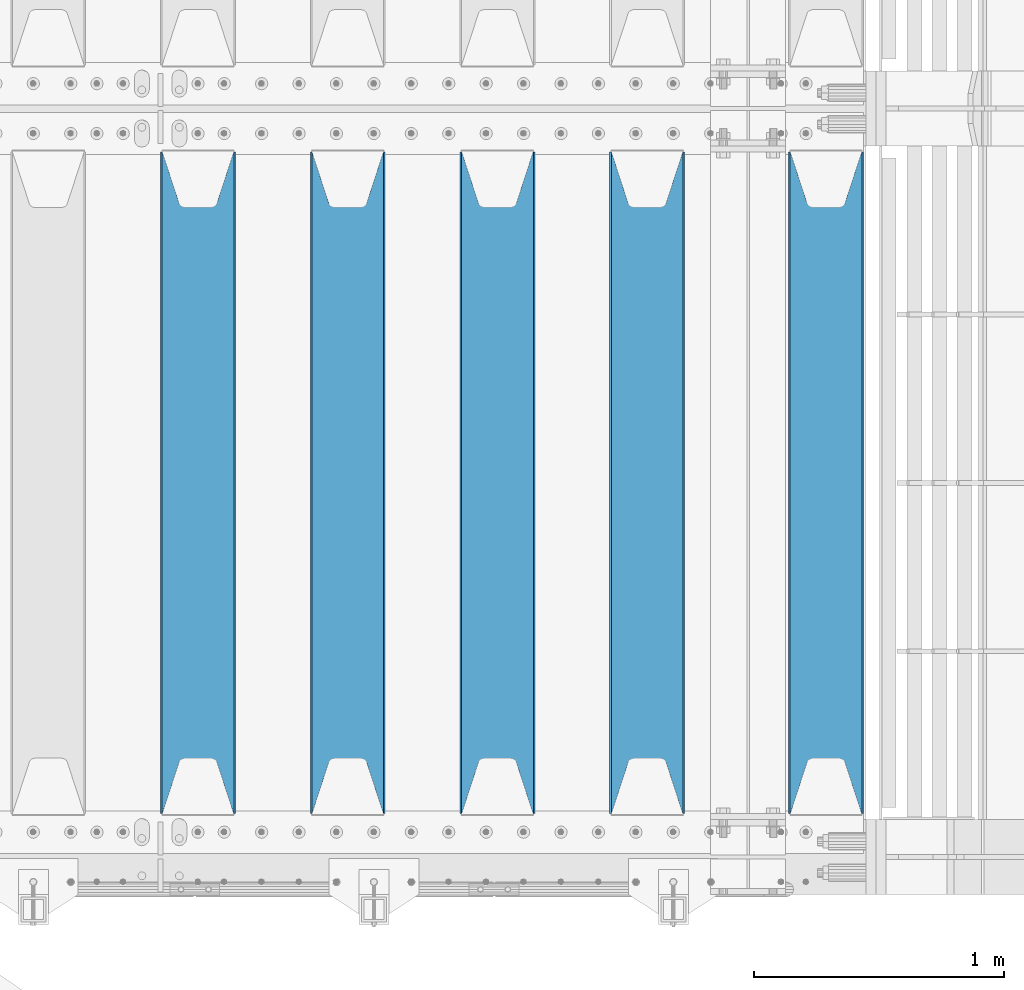
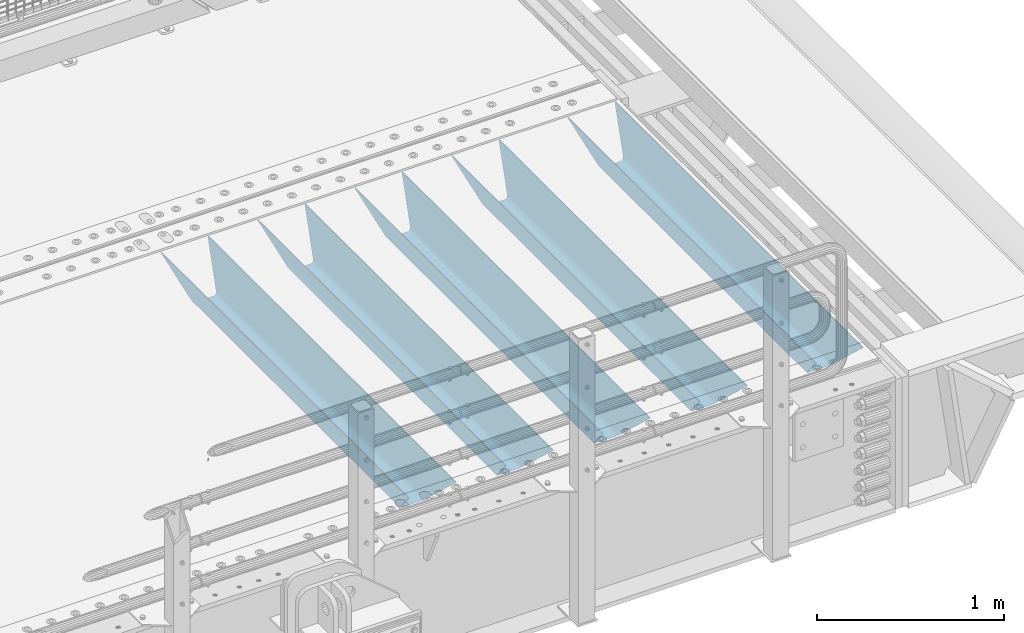
# One storey, part 96 of 193: 5 beams.
"""IFC2X3 building model written with IfcOpenShell, lengths in millimetres."""

from ifc_helpers import new_model, si_unit, frame, origin_with_axes, place, context, subcontext, project, spatial, faceted_brep, material, type_object, element, save


model = new_model("IFC2X3")

# Units and contexts
model_context = context("Model", 3, precision=1e-05, world=origin_with_axes())
body_context = subcontext(model_context, "Body", "Model", "MODEL_VIEW")
ifc_project = project(units=[si_unit("LENGTHUNIT", "METRE", prefix="MILLI"), si_unit("AREAUNIT", "SQUARE_METRE"), si_unit("VOLUMEUNIT", "CUBIC_METRE"), si_unit("MASSUNIT", "GRAM", prefix="KILO"), si_unit("TIMEUNIT", "SECOND"), si_unit("PLANEANGLEUNIT", "RADIAN"), si_unit("SOLIDANGLEUNIT", "STERADIAN"), si_unit("THERMODYNAMICTEMPERATUREUNIT", "DEGREE_CELSIUS"), si_unit("LUMINOUSINTENSITYUNIT", "LUMEN")], contexts=[model_context])

# Site, building, storey
site_placement = place(None, origin_with_axes())
site = spatial("IfcSite", under=ifc_project, at=site_placement, CompositionType="ELEMENT")
building_placement = place(site_placement, origin_with_axes())
building = spatial("IfcBuilding", under=site, at=building_placement, Name="Standard", CompositionType="ELEMENT")
storey_placement = place(building_placement, origin_with_axes())
storey = spatial("IfcBuildingStorey", under=building, at=storey_placement, Name="Undefined", CompositionType="ELEMENT", Elevation=0.0)

# Beams
ifc_material = material(Name="STEEL/S355N")
beam_type = type_object("IfcBeamType", PredefinedType="NOTDEFINED")
beam_1_placement = place(storey_placement, frame((-28583.0, 24175.0, -115.0), z_axis=(0.0, 0.0, 1.0), x_axis=(0.0, 1.0, 0.0)))
element("IfcBeam", 1, at=beam_1_placement, inside=storey, type_object=beam_type, material=ifc_material, context=body_context, shape_type="Brep", body=[
    faceted_brep([(0.0, 150.0, 115.0), (0.0, 143.689999999999, 115.0), (2650.00000000297, 143.689999999999, 115.0), (2650.00000000297, 150.0, 115.0), (2650.00000000297, 142.059565218398, 110.000000003094), (2650.00000000297, 148.3695652184, 110.000000003094), (2441.90079219209, -80.1103600731112, -98.0992078077845), (2437.7588105432, -77.5672621345584, -102.241189456673), (2434.06523489747, -74.4080125315522, -105.934765102404), (2430.9108609509, -70.710272125576, -109.089139048974), (2428.37322971128, -66.5649389910068, -111.626770288588), (2426.51472138055, -62.0739139532889, -113.485278619323), (2425.38102192092, -57.3475956567672, -114.618978078955), (2424.99999999988, -52.5021667386536, -115.0), (2424.99999999988, 52.5021667386536, -115.0), (2425.38102192092, 57.3475956567672, -114.618978078955), (2426.51472138055, 62.0739139532889, -113.485278619323), (2428.37322971128, 66.5649389910068, -111.626770288588), (2430.9108609509, 70.710272125576, -109.089139048974), (2434.06523489747, 74.4080125315522, -105.934765102404), (2437.7588105432, 77.5672621345584, -102.241189456673), (2441.90079219209, 80.1103600731112, -98.0992078077846), (2446.38936140512, 81.9747917625791, -93.6106385947584), (2448.2494850041, 76.2713538057251, -91.7505149957729), (2444.62967112263, 74.76777986261, -95.3703288772456), (2441.28936334127, 72.7168944282894, -98.710636658607), (2438.31067330439, 70.1691124903846, -101.689326695487), (2435.76682334748, 67.1870637758839, -104.233176652398), (2433.72034654134, 63.8440531834895, -106.279653458539), (2432.22154950042, 60.222258798236, -107.778450499454), (2431.30727574265, 56.4107117849089, -108.692724257221), (2430.99999999987, 52.5031078186876, -109.0), (2430.99999999987, -52.5031078186876, -109.0), (2431.30727574265, -56.4107117849089, -108.692724257221), (2432.22154950042, -60.222258798236, -107.778450499454), (2433.72034654134, -63.8440531834895, -106.279653458539), (2435.76682334748, -67.1870637758839, -104.233176652398), (2438.31067330439, -70.1691124903846, -101.689326695487), (2441.28936334127, -72.7168944282894, -98.7106366586071), (2444.62967112263, -74.76777986261, -95.3703288772457), (2448.2494850041, -76.2713538057251, -91.7505149957729), (2650.00000000297, -142.059565218398, 110.000000003094), (2650.00000000297, -148.3695652184, 110.000000003094), (2446.38936140512, -81.9747917625791, -93.6106385947584), (2650.00000000297, -143.689999999999, 115.0), (2650.00000000297, -150.0, 115.0), (0.0, -143.689999999999, 115.0), (0.0, -150.0, 115.0), (0.0, -148.369565218261, 110.000000002667), (203.610638597427, -81.9747917625791, -93.6106385947584), (208.099207810446, -80.1103600731112, -98.0992078077845), (212.241189459342, -77.5672621345584, -102.241189456673), (215.93476510507, -74.4080125315522, -105.934765102404), (219.089139051641, -70.710272125576, -109.089139048974), (221.626770291256, -66.5649389910068, -111.626770288588), (223.485278621989, -62.0739139532889, -113.485278619323), (224.618978081624, -57.3475956567672, -114.618978078955), (225.000000002663, -52.5021667386536, -115.0), (225.000000002663, 52.5021667386536, -115.0), (224.618978081624, 57.3475956567672, -114.618978078955), (223.485278621989, 62.0739139532889, -113.485278619323), (221.626770291256, 66.5649389910068, -111.626770288588), (219.089139051641, 70.710272125576, -109.089139048974), (215.93476510507, 74.4080125315522, -105.934765102404), (212.241189459342, 77.5672621345584, -102.241189456673), (208.099207810446, 80.1103600731112, -98.0992078077846), (203.610638597427, 81.9747917625791, -93.6106385947584), (0.0, 148.369565218261, 110.000000002667), (0.0, 142.05956521826, 110.000000002667), (201.750514998439, 76.2713538057251, -91.7505149957729), (205.370328879915, 74.76777986261, -95.3703288772456), (208.710636661275, 72.7168944282894, -98.710636658607), (211.689326698157, 70.1691124903846, -101.689326695487), (214.233176655063, 67.1870637758839, -104.233176652398), (216.279653461206, 63.8440531834895, -106.279653458539), (217.778450502123, 60.222258798236, -107.778450499454), (218.69272425989, 56.4107117849089, -108.692724257221), (219.00000000267, 52.5031078186876, -109.0), (219.00000000267, -52.5031078186876, -109.0), (218.69272425989, -56.4107117849089, -108.692724257221), (217.778450502123, -60.222258798236, -107.778450499454), (216.279653461206, -63.8440531834895, -106.279653458539), (214.233176655063, -67.1870637758839, -104.233176652398), (211.689326698157, -70.1691124903846, -101.689326695487), (208.710636661275, -72.7168944282894, -98.7106366586071), (205.370328879915, -74.76777986261, -95.3703288772457), (201.750514998439, -76.2713538057251, -91.7505149957729), (0.0, -142.05956521826, 110.000000002667)], [[[0, 1, 2, 3]], [[3, 2, 4, 5]], [[6, 7, 8, 9, 10, 11, 12, 13, 14, 15, 16, 17, 18, 19, 20, 21, 22, 5, 4, 23, 24, 25, 26, 27, 28, 29, 30, 31, 32, 33, 34, 35, 36, 37, 38, 39, 40, 41, 42, 43]], [[44, 45, 42, 41]], [[46, 47, 45, 44]], [[43, 42, 45, 47, 48, 49]], [[6, 43, 49, 50]], [[7, 6, 50, 51]], [[8, 7, 51, 52]], [[9, 8, 52, 53]], [[10, 9, 53, 54]], [[11, 10, 54, 55]], [[12, 11, 55, 56]], [[13, 12, 56, 57]], [[14, 13, 57, 58]], [[15, 14, 58, 59]], [[16, 15, 59, 60]], [[17, 16, 60, 61]], [[18, 17, 61, 62]], [[19, 18, 62, 63]], [[20, 19, 63, 64]], [[21, 20, 64, 65]], [[22, 21, 65, 66]], [[0, 3, 5, 22, 66, 67]], [[1, 0, 67, 68]], [[23, 4, 2, 1, 68, 69]], [[24, 23, 69, 70]], [[25, 24, 70, 71]], [[26, 25, 71, 72]], [[27, 26, 72, 73]], [[28, 27, 73, 74]], [[29, 28, 74, 75]], [[30, 29, 75, 76]], [[31, 30, 76, 77]], [[32, 31, 77, 78]], [[33, 32, 78, 79]], [[34, 33, 79, 80]], [[35, 34, 80, 81]], [[36, 35, 81, 82]], [[37, 36, 82, 83]], [[38, 37, 83, 84]], [[39, 38, 84, 85]], [[40, 39, 85, 86]], [[46, 44, 41, 40, 86, 87]], [[47, 46, 87, 48]], [[86, 85, 84, 83, 82, 81, 80, 79, 78, 77, 76, 75, 74, 73, 72, 71, 70, 69, 68, 67, 66, 65, 64, 63, 62, 61, 60, 59, 58, 57, 56, 55, 54, 53, 52, 51, 50, 49, 48, 87]]]),
])
beam_2_placement = place(storey_placement, frame((-29300.0, 24175.0, -115.0), z_axis=(0.0, 0.0, 1.0), x_axis=(0.0, 1.0, 0.0)))
element("IfcBeam", 2, at=beam_2_placement, inside=storey, type_object=beam_type, material=ifc_material, context=body_context, shape_type="Brep", body=[
    faceted_brep([(0.0, 150.0, 115.0), (0.0, 143.689999999999, 115.0), (2650.00000000297, 143.689999999999, 115.0), (2650.00000000297, 150.0, 115.0), (2650.00000000297, 142.059565218398, 110.000000003094), (2650.00000000297, 148.3695652184, 110.000000003094), (2441.90079219209, -80.1103600731112, -98.0992078077845), (2437.7588105432, -77.5672621345584, -102.241189456673), (2434.06523489747, -74.4080125315522, -105.934765102404), (2430.9108609509, -70.710272125576, -109.089139048974), (2428.37322971128, -66.5649389910068, -111.626770288588), (2426.51472138055, -62.0739139532889, -113.485278619323), (2425.38102192092, -57.3475956567672, -114.618978078955), (2424.99999999988, -52.5021667386536, -115.0), (2424.99999999988, 52.5021667386536, -115.0), (2425.38102192092, 57.3475956567672, -114.618978078955), (2426.51472138055, 62.0739139532889, -113.485278619323), (2428.37322971128, 66.5649389910068, -111.626770288588), (2430.9108609509, 70.710272125576, -109.089139048974), (2434.06523489747, 74.4080125315522, -105.934765102404), (2437.7588105432, 77.5672621345584, -102.241189456673), (2441.90079219209, 80.1103600731112, -98.0992078077846), (2446.38936140512, 81.9747917625791, -93.6106385947584), (2448.2494850041, 76.2713538057251, -91.7505149957729), (2444.62967112263, 74.76777986261, -95.3703288772456), (2441.28936334127, 72.7168944282894, -98.710636658607), (2438.31067330439, 70.1691124903846, -101.689326695487), (2435.76682334748, 67.1870637758839, -104.233176652398), (2433.72034654134, 63.8440531834895, -106.279653458539), (2432.22154950042, 60.222258798236, -107.778450499454), (2431.30727574265, 56.4107117849089, -108.692724257221), (2430.99999999987, 52.5031078186876, -109.0), (2430.99999999987, -52.5031078186876, -109.0), (2431.30727574265, -56.4107117849089, -108.692724257221), (2432.22154950042, -60.222258798236, -107.778450499454), (2433.72034654134, -63.8440531834895, -106.279653458539), (2435.76682334748, -67.1870637758839, -104.233176652398), (2438.31067330439, -70.1691124903846, -101.689326695487), (2441.28936334127, -72.7168944282894, -98.7106366586071), (2444.62967112263, -74.76777986261, -95.3703288772457), (2448.2494850041, -76.2713538057251, -91.7505149957729), (2650.00000000297, -142.059565218398, 110.000000003094), (2650.00000000297, -148.3695652184, 110.000000003094), (2446.38936140512, -81.9747917625791, -93.6106385947584), (2650.00000000297, -143.689999999999, 115.0), (2650.00000000297, -150.0, 115.0), (0.0, -143.689999999999, 115.0), (0.0, -150.0, 115.0), (0.0, -148.369565218261, 110.000000002667), (203.610638597427, -81.9747917625791, -93.6106385947584), (208.099207810446, -80.1103600731112, -98.0992078077845), (212.241189459342, -77.5672621345584, -102.241189456673), (215.93476510507, -74.4080125315522, -105.934765102404), (219.089139051641, -70.710272125576, -109.089139048974), (221.626770291256, -66.5649389910068, -111.626770288588), (223.485278621989, -62.0739139532889, -113.485278619323), (224.618978081624, -57.3475956567672, -114.618978078955), (225.000000002663, -52.5021667386536, -115.0), (225.000000002663, 52.5021667386536, -115.0), (224.618978081624, 57.3475956567672, -114.618978078955), (223.485278621989, 62.0739139532889, -113.485278619323), (221.626770291256, 66.5649389910068, -111.626770288588), (219.089139051641, 70.710272125576, -109.089139048974), (215.93476510507, 74.4080125315522, -105.934765102404), (212.241189459342, 77.5672621345584, -102.241189456673), (208.099207810446, 80.1103600731112, -98.0992078077846), (203.610638597427, 81.9747917625791, -93.6106385947584), (0.0, 148.369565218261, 110.000000002667), (0.0, 142.05956521826, 110.000000002667), (201.750514998439, 76.2713538057251, -91.7505149957729), (205.370328879915, 74.76777986261, -95.3703288772456), (208.710636661275, 72.7168944282894, -98.710636658607), (211.689326698157, 70.1691124903846, -101.689326695487), (214.233176655063, 67.1870637758839, -104.233176652398), (216.279653461206, 63.8440531834895, -106.279653458539), (217.778450502123, 60.222258798236, -107.778450499454), (218.69272425989, 56.4107117849089, -108.692724257221), (219.00000000267, 52.5031078186876, -109.0), (219.00000000267, -52.5031078186876, -109.0), (218.69272425989, -56.4107117849089, -108.692724257221), (217.778450502123, -60.222258798236, -107.778450499454), (216.279653461206, -63.8440531834895, -106.279653458539), (214.233176655063, -67.1870637758839, -104.233176652398), (211.689326698157, -70.1691124903846, -101.689326695487), (208.710636661275, -72.7168944282894, -98.7106366586071), (205.370328879915, -74.76777986261, -95.3703288772457), (201.750514998439, -76.2713538057251, -91.7505149957729), (0.0, -142.05956521826, 110.000000002667)], [[[0, 1, 2, 3]], [[3, 2, 4, 5]], [[6, 7, 8, 9, 10, 11, 12, 13, 14, 15, 16, 17, 18, 19, 20, 21, 22, 5, 4, 23, 24, 25, 26, 27, 28, 29, 30, 31, 32, 33, 34, 35, 36, 37, 38, 39, 40, 41, 42, 43]], [[44, 45, 42, 41]], [[46, 47, 45, 44]], [[43, 42, 45, 47, 48, 49]], [[6, 43, 49, 50]], [[7, 6, 50, 51]], [[8, 7, 51, 52]], [[9, 8, 52, 53]], [[10, 9, 53, 54]], [[11, 10, 54, 55]], [[12, 11, 55, 56]], [[13, 12, 56, 57]], [[14, 13, 57, 58]], [[15, 14, 58, 59]], [[16, 15, 59, 60]], [[17, 16, 60, 61]], [[18, 17, 61, 62]], [[19, 18, 62, 63]], [[20, 19, 63, 64]], [[21, 20, 64, 65]], [[22, 21, 65, 66]], [[0, 3, 5, 22, 66, 67]], [[1, 0, 67, 68]], [[23, 4, 2, 1, 68, 69]], [[24, 23, 69, 70]], [[25, 24, 70, 71]], [[26, 25, 71, 72]], [[27, 26, 72, 73]], [[28, 27, 73, 74]], [[29, 28, 74, 75]], [[30, 29, 75, 76]], [[31, 30, 76, 77]], [[32, 31, 77, 78]], [[33, 32, 78, 79]], [[34, 33, 79, 80]], [[35, 34, 80, 81]], [[36, 35, 81, 82]], [[37, 36, 82, 83]], [[38, 37, 83, 84]], [[39, 38, 84, 85]], [[40, 39, 85, 86]], [[46, 44, 41, 40, 86, 87]], [[47, 46, 87, 48]], [[86, 85, 84, 83, 82, 81, 80, 79, 78, 77, 76, 75, 74, 73, 72, 71, 70, 69, 68, 67, 66, 65, 64, 63, 62, 61, 60, 59, 58, 57, 56, 55, 54, 53, 52, 51, 50, 49, 48, 87]]]),
])
beam_3_placement = place(storey_placement, frame((-29900.0, 24175.0, -115.0), z_axis=(0.0, 0.0, 1.0), x_axis=(0.0, 1.0, 0.0)))
element("IfcBeam", 3, at=beam_3_placement, inside=storey, type_object=beam_type, material=ifc_material, context=body_context, shape_type="Brep", body=[
    faceted_brep([(0.0, 150.0, 115.0), (0.0, 143.689999999999, 115.0), (2650.00000000297, 143.689999999999, 115.0), (2650.00000000297, 150.0, 115.0), (2650.00000000297, 142.059565218398, 110.000000003094), (2650.00000000297, 148.3695652184, 110.000000003094), (2441.90079219209, -80.1103600731112, -98.0992078077845), (2437.7588105432, -77.5672621345584, -102.241189456673), (2434.06523489747, -74.4080125315522, -105.934765102404), (2430.9108609509, -70.710272125576, -109.089139048974), (2428.37322971128, -66.5649389910068, -111.626770288588), (2426.51472138055, -62.0739139532889, -113.485278619323), (2425.38102192092, -57.3475956567672, -114.618978078955), (2424.99999999988, -52.5021667386536, -115.0), (2424.99999999988, 52.5021667386536, -115.0), (2425.38102192092, 57.3475956567672, -114.618978078955), (2426.51472138055, 62.0739139532889, -113.485278619323), (2428.37322971128, 66.5649389910068, -111.626770288588), (2430.9108609509, 70.710272125576, -109.089139048974), (2434.06523489747, 74.4080125315522, -105.934765102404), (2437.7588105432, 77.5672621345584, -102.241189456673), (2441.90079219209, 80.1103600731112, -98.0992078077846), (2446.38936140512, 81.9747917625791, -93.6106385947584), (2448.2494850041, 76.2713538057251, -91.7505149957729), (2444.62967112263, 74.76777986261, -95.3703288772456), (2441.28936334127, 72.7168944282894, -98.710636658607), (2438.31067330439, 70.1691124903846, -101.689326695487), (2435.76682334748, 67.1870637758839, -104.233176652398), (2433.72034654134, 63.8440531834895, -106.279653458539), (2432.22154950042, 60.222258798236, -107.778450499454), (2431.30727574265, 56.4107117849089, -108.692724257221), (2430.99999999987, 52.5031078186876, -109.0), (2430.99999999987, -52.5031078186876, -109.0), (2431.30727574265, -56.4107117849089, -108.692724257221), (2432.22154950042, -60.222258798236, -107.778450499454), (2433.72034654134, -63.8440531834895, -106.279653458539), (2435.76682334748, -67.1870637758839, -104.233176652398), (2438.31067330439, -70.1691124903846, -101.689326695487), (2441.28936334127, -72.7168944282894, -98.7106366586071), (2444.62967112263, -74.76777986261, -95.3703288772457), (2448.2494850041, -76.2713538057251, -91.7505149957729), (2650.00000000297, -142.059565218398, 110.000000003094), (2650.00000000297, -148.3695652184, 110.000000003094), (2446.38936140512, -81.9747917625791, -93.6106385947584), (2650.00000000297, -143.689999999999, 115.0), (2650.00000000297, -150.0, 115.0), (0.0, -143.689999999999, 115.0), (0.0, -150.0, 115.0), (0.0, -148.369565218261, 110.000000002667), (203.610638597427, -81.9747917625791, -93.6106385947584), (208.099207810446, -80.1103600731112, -98.0992078077845), (212.241189459342, -77.5672621345584, -102.241189456673), (215.93476510507, -74.4080125315522, -105.934765102404), (219.089139051641, -70.710272125576, -109.089139048974), (221.626770291256, -66.5649389910068, -111.626770288588), (223.485278621989, -62.0739139532889, -113.485278619323), (224.618978081624, -57.3475956567672, -114.618978078955), (225.000000002663, -52.5021667386536, -115.0), (225.000000002663, 52.5021667386536, -115.0), (224.618978081624, 57.3475956567672, -114.618978078955), (223.485278621989, 62.0739139532889, -113.485278619323), (221.626770291256, 66.5649389910068, -111.626770288588), (219.089139051641, 70.710272125576, -109.089139048974), (215.93476510507, 74.4080125315522, -105.934765102404), (212.241189459342, 77.5672621345584, -102.241189456673), (208.099207810446, 80.1103600731112, -98.0992078077846), (203.610638597427, 81.9747917625791, -93.6106385947584), (0.0, 148.369565218261, 110.000000002667), (0.0, 142.05956521826, 110.000000002667), (201.750514998439, 76.2713538057251, -91.7505149957729), (205.370328879915, 74.76777986261, -95.3703288772456), (208.710636661275, 72.7168944282894, -98.710636658607), (211.689326698157, 70.1691124903846, -101.689326695487), (214.233176655063, 67.1870637758839, -104.233176652398), (216.279653461206, 63.8440531834895, -106.279653458539), (217.778450502123, 60.222258798236, -107.778450499454), (218.69272425989, 56.4107117849089, -108.692724257221), (219.00000000267, 52.5031078186876, -109.0), (219.00000000267, -52.5031078186876, -109.0), (218.69272425989, -56.4107117849089, -108.692724257221), (217.778450502123, -60.222258798236, -107.778450499454), (216.279653461206, -63.8440531834895, -106.279653458539), (214.233176655063, -67.1870637758839, -104.233176652398), (211.689326698157, -70.1691124903846, -101.689326695487), (208.710636661275, -72.7168944282894, -98.7106366586071), (205.370328879915, -74.76777986261, -95.3703288772457), (201.750514998439, -76.2713538057251, -91.7505149957729), (0.0, -142.05956521826, 110.000000002667)], [[[0, 1, 2, 3]], [[3, 2, 4, 5]], [[6, 7, 8, 9, 10, 11, 12, 13, 14, 15, 16, 17, 18, 19, 20, 21, 22, 5, 4, 23, 24, 25, 26, 27, 28, 29, 30, 31, 32, 33, 34, 35, 36, 37, 38, 39, 40, 41, 42, 43]], [[44, 45, 42, 41]], [[46, 47, 45, 44]], [[43, 42, 45, 47, 48, 49]], [[6, 43, 49, 50]], [[7, 6, 50, 51]], [[8, 7, 51, 52]], [[9, 8, 52, 53]], [[10, 9, 53, 54]], [[11, 10, 54, 55]], [[12, 11, 55, 56]], [[13, 12, 56, 57]], [[14, 13, 57, 58]], [[15, 14, 58, 59]], [[16, 15, 59, 60]], [[17, 16, 60, 61]], [[18, 17, 61, 62]], [[19, 18, 62, 63]], [[20, 19, 63, 64]], [[21, 20, 64, 65]], [[22, 21, 65, 66]], [[0, 3, 5, 22, 66, 67]], [[1, 0, 67, 68]], [[23, 4, 2, 1, 68, 69]], [[24, 23, 69, 70]], [[25, 24, 70, 71]], [[26, 25, 71, 72]], [[27, 26, 72, 73]], [[28, 27, 73, 74]], [[29, 28, 74, 75]], [[30, 29, 75, 76]], [[31, 30, 76, 77]], [[32, 31, 77, 78]], [[33, 32, 78, 79]], [[34, 33, 79, 80]], [[35, 34, 80, 81]], [[36, 35, 81, 82]], [[37, 36, 82, 83]], [[38, 37, 83, 84]], [[39, 38, 84, 85]], [[40, 39, 85, 86]], [[46, 44, 41, 40, 86, 87]], [[47, 46, 87, 48]], [[86, 85, 84, 83, 82, 81, 80, 79, 78, 77, 76, 75, 74, 73, 72, 71, 70, 69, 68, 67, 66, 65, 64, 63, 62, 61, 60, 59, 58, 57, 56, 55, 54, 53, 52, 51, 50, 49, 48, 87]]]),
])
beam_4_placement = place(storey_placement, frame((-30500.0, 24175.0, -115.0), z_axis=(0.0, 0.0, 1.0), x_axis=(0.0, 1.0, 0.0)))
element("IfcBeam", 4, at=beam_4_placement, inside=storey, type_object=beam_type, material=ifc_material, context=body_context, shape_type="Brep", body=[
    faceted_brep([(0.0, 150.0, 115.0), (0.0, 143.689999999999, 115.0), (2650.00000000297, 143.689999999999, 115.0), (2650.00000000297, 150.0, 115.0), (2650.00000000297, 142.059565218398, 110.000000003094), (2650.00000000297, 148.3695652184, 110.000000003094), (2441.90079219209, -80.1103600731112, -98.0992078077845), (2437.7588105432, -77.5672621345584, -102.241189456673), (2434.06523489747, -74.4080125315522, -105.934765102404), (2430.9108609509, -70.710272125576, -109.089139048974), (2428.37322971128, -66.5649389910068, -111.626770288588), (2426.51472138055, -62.0739139532889, -113.485278619323), (2425.38102192092, -57.3475956567672, -114.618978078955), (2424.99999999988, -52.5021667386536, -115.0), (2424.99999999988, 52.5021667386536, -115.0), (2425.38102192092, 57.3475956567672, -114.618978078955), (2426.51472138055, 62.0739139532889, -113.485278619323), (2428.37322971128, 66.5649389910068, -111.626770288588), (2430.9108609509, 70.710272125576, -109.089139048974), (2434.06523489747, 74.4080125315522, -105.934765102404), (2437.7588105432, 77.5672621345584, -102.241189456673), (2441.90079219209, 80.1103600731112, -98.0992078077846), (2446.38936140512, 81.9747917625791, -93.6106385947584), (2448.2494850041, 76.2713538057251, -91.7505149957729), (2444.62967112263, 74.76777986261, -95.3703288772456), (2441.28936334127, 72.7168944282894, -98.710636658607), (2438.31067330439, 70.1691124903846, -101.689326695487), (2435.76682334748, 67.1870637758839, -104.233176652398), (2433.72034654134, 63.8440531834895, -106.279653458539), (2432.22154950042, 60.222258798236, -107.778450499454), (2431.30727574265, 56.4107117849089, -108.692724257221), (2430.99999999987, 52.5031078186876, -109.0), (2430.99999999987, -52.5031078186876, -109.0), (2431.30727574265, -56.4107117849089, -108.692724257221), (2432.22154950042, -60.222258798236, -107.778450499454), (2433.72034654134, -63.8440531834895, -106.279653458539), (2435.76682334748, -67.1870637758839, -104.233176652398), (2438.31067330439, -70.1691124903846, -101.689326695487), (2441.28936334127, -72.7168944282894, -98.7106366586071), (2444.62967112263, -74.76777986261, -95.3703288772457), (2448.2494850041, -76.2713538057251, -91.7505149957729), (2650.00000000297, -142.059565218398, 110.000000003094), (2650.00000000297, -148.3695652184, 110.000000003094), (2446.38936140512, -81.9747917625791, -93.6106385947584), (2650.00000000297, -143.689999999999, 115.0), (2650.00000000297, -150.0, 115.0), (0.0, -143.689999999999, 115.0), (0.0, -150.0, 115.0), (0.0, -148.369565218261, 110.000000002667), (203.610638597427, -81.9747917625791, -93.6106385947584), (208.099207810446, -80.1103600731112, -98.0992078077845), (212.241189459342, -77.5672621345584, -102.241189456673), (215.93476510507, -74.4080125315522, -105.934765102404), (219.089139051641, -70.710272125576, -109.089139048974), (221.626770291256, -66.5649389910068, -111.626770288588), (223.485278621989, -62.0739139532889, -113.485278619323), (224.618978081624, -57.3475956567672, -114.618978078955), (225.000000002663, -52.5021667386536, -115.0), (225.000000002663, 52.5021667386536, -115.0), (224.618978081624, 57.3475956567672, -114.618978078955), (223.485278621989, 62.0739139532889, -113.485278619323), (221.626770291256, 66.5649389910068, -111.626770288588), (219.089139051641, 70.710272125576, -109.089139048974), (215.93476510507, 74.4080125315522, -105.934765102404), (212.241189459342, 77.5672621345584, -102.241189456673), (208.099207810446, 80.1103600731112, -98.0992078077846), (203.610638597427, 81.9747917625791, -93.6106385947584), (0.0, 148.369565218261, 110.000000002667), (0.0, 142.05956521826, 110.000000002667), (201.750514998439, 76.2713538057251, -91.7505149957729), (205.370328879915, 74.76777986261, -95.3703288772456), (208.710636661275, 72.7168944282894, -98.710636658607), (211.689326698157, 70.1691124903846, -101.689326695487), (214.233176655063, 67.1870637758839, -104.233176652398), (216.279653461206, 63.8440531834895, -106.279653458539), (217.778450502123, 60.222258798236, -107.778450499454), (218.69272425989, 56.4107117849089, -108.692724257221), (219.00000000267, 52.5031078186876, -109.0), (219.00000000267, -52.5031078186876, -109.0), (218.69272425989, -56.4107117849089, -108.692724257221), (217.778450502123, -60.222258798236, -107.778450499454), (216.279653461206, -63.8440531834895, -106.279653458539), (214.233176655063, -67.1870637758839, -104.233176652398), (211.689326698157, -70.1691124903846, -101.689326695487), (208.710636661275, -72.7168944282894, -98.7106366586071), (205.370328879915, -74.76777986261, -95.3703288772457), (201.750514998439, -76.2713538057251, -91.7505149957729), (0.0, -142.05956521826, 110.000000002667)], [[[0, 1, 2, 3]], [[3, 2, 4, 5]], [[6, 7, 8, 9, 10, 11, 12, 13, 14, 15, 16, 17, 18, 19, 20, 21, 22, 5, 4, 23, 24, 25, 26, 27, 28, 29, 30, 31, 32, 33, 34, 35, 36, 37, 38, 39, 40, 41, 42, 43]], [[44, 45, 42, 41]], [[46, 47, 45, 44]], [[43, 42, 45, 47, 48, 49]], [[6, 43, 49, 50]], [[7, 6, 50, 51]], [[8, 7, 51, 52]], [[9, 8, 52, 53]], [[10, 9, 53, 54]], [[11, 10, 54, 55]], [[12, 11, 55, 56]], [[13, 12, 56, 57]], [[14, 13, 57, 58]], [[15, 14, 58, 59]], [[16, 15, 59, 60]], [[17, 16, 60, 61]], [[18, 17, 61, 62]], [[19, 18, 62, 63]], [[20, 19, 63, 64]], [[21, 20, 64, 65]], [[22, 21, 65, 66]], [[0, 3, 5, 22, 66, 67]], [[1, 0, 67, 68]], [[23, 4, 2, 1, 68, 69]], [[24, 23, 69, 70]], [[25, 24, 70, 71]], [[26, 25, 71, 72]], [[27, 26, 72, 73]], [[28, 27, 73, 74]], [[29, 28, 74, 75]], [[30, 29, 75, 76]], [[31, 30, 76, 77]], [[32, 31, 77, 78]], [[33, 32, 78, 79]], [[34, 33, 79, 80]], [[35, 34, 80, 81]], [[36, 35, 81, 82]], [[37, 36, 82, 83]], [[38, 37, 83, 84]], [[39, 38, 84, 85]], [[40, 39, 85, 86]], [[46, 44, 41, 40, 86, 87]], [[47, 46, 87, 48]], [[86, 85, 84, 83, 82, 81, 80, 79, 78, 77, 76, 75, 74, 73, 72, 71, 70, 69, 68, 67, 66, 65, 64, 63, 62, 61, 60, 59, 58, 57, 56, 55, 54, 53, 52, 51, 50, 49, 48, 87]]]),
])
beam_5_placement = place(storey_placement, frame((-31100.0, 24175.0, -115.0), z_axis=(0.0, 0.0, 1.0), x_axis=(0.0, 1.0, 0.0)))
element("IfcBeam", 5, at=beam_5_placement, inside=storey, type_object=beam_type, material=ifc_material, context=body_context, shape_type="Brep", body=[
    faceted_brep([(0.0, 150.0, 115.0), (0.0, 143.689999999999, 115.0), (2650.00000000297, 143.689999999999, 115.0), (2650.00000000297, 150.0, 115.0), (2650.00000000297, 142.059565218398, 110.000000003094), (2650.00000000297, 148.3695652184, 110.000000003094), (2441.90079219209, -80.1103600731112, -98.0992078077845), (2437.7588105432, -77.5672621345584, -102.241189456673), (2434.06523489747, -74.4080125315522, -105.934765102404), (2430.9108609509, -70.710272125576, -109.089139048974), (2428.37322971128, -66.5649389910068, -111.626770288588), (2426.51472138055, -62.0739139532889, -113.485278619323), (2425.38102192092, -57.3475956567672, -114.618978078955), (2424.99999999988, -52.5021667386536, -115.0), (2424.99999999988, 52.5021667386536, -115.0), (2425.38102192092, 57.3475956567672, -114.618978078955), (2426.51472138055, 62.0739139532889, -113.485278619323), (2428.37322971128, 66.5649389910068, -111.626770288588), (2430.9108609509, 70.710272125576, -109.089139048974), (2434.06523489747, 74.4080125315522, -105.934765102404), (2437.7588105432, 77.5672621345584, -102.241189456673), (2441.90079219209, 80.1103600731112, -98.0992078077846), (2446.38936140512, 81.9747917625791, -93.6106385947584), (2448.2494850041, 76.2713538057251, -91.7505149957729), (2444.62967112263, 74.76777986261, -95.3703288772456), (2441.28936334127, 72.7168944282894, -98.710636658607), (2438.31067330439, 70.1691124903846, -101.689326695487), (2435.76682334748, 67.1870637758839, -104.233176652398), (2433.72034654134, 63.8440531834895, -106.279653458539), (2432.22154950042, 60.222258798236, -107.778450499454), (2431.30727574265, 56.4107117849089, -108.692724257221), (2430.99999999987, 52.5031078186876, -109.0), (2430.99999999987, -52.5031078186876, -109.0), (2431.30727574265, -56.4107117849089, -108.692724257221), (2432.22154950042, -60.222258798236, -107.778450499454), (2433.72034654134, -63.8440531834895, -106.279653458539), (2435.76682334748, -67.1870637758839, -104.233176652398), (2438.31067330439, -70.1691124903846, -101.689326695487), (2441.28936334127, -72.7168944282894, -98.7106366586071), (2444.62967112263, -74.76777986261, -95.3703288772457), (2448.2494850041, -76.2713538057251, -91.7505149957729), (2650.00000000297, -142.059565218398, 110.000000003094), (2650.00000000297, -148.3695652184, 110.000000003094), (2446.38936140512, -81.9747917625791, -93.6106385947584), (2650.00000000297, -143.689999999999, 115.0), (2650.00000000297, -150.0, 115.0), (0.0, -143.689999999999, 115.0), (0.0, -150.0, 115.0), (0.0, -148.369565218261, 110.000000002667), (203.610638597427, -81.9747917625791, -93.6106385947584), (208.099207810446, -80.1103600731112, -98.0992078077845), (212.241189459342, -77.5672621345584, -102.241189456673), (215.93476510507, -74.4080125315522, -105.934765102404), (219.089139051641, -70.710272125576, -109.089139048974), (221.626770291256, -66.5649389910068, -111.626770288588), (223.485278621989, -62.0739139532889, -113.485278619323), (224.618978081624, -57.3475956567672, -114.618978078955), (225.000000002663, -52.5021667386536, -115.0), (225.000000002663, 52.5021667386536, -115.0), (224.618978081624, 57.3475956567672, -114.618978078955), (223.485278621989, 62.0739139532889, -113.485278619323), (221.626770291256, 66.5649389910068, -111.626770288588), (219.089139051641, 70.710272125576, -109.089139048974), (215.93476510507, 74.4080125315522, -105.934765102404), (212.241189459342, 77.5672621345584, -102.241189456673), (208.099207810446, 80.1103600731112, -98.0992078077846), (203.610638597427, 81.9747917625791, -93.6106385947584), (0.0, 148.369565218261, 110.000000002667), (0.0, 142.05956521826, 110.000000002667), (201.750514998439, 76.2713538057251, -91.7505149957729), (205.370328879915, 74.76777986261, -95.3703288772456), (208.710636661275, 72.7168944282894, -98.710636658607), (211.689326698157, 70.1691124903846, -101.689326695487), (214.233176655063, 67.1870637758839, -104.233176652398), (216.279653461206, 63.8440531834895, -106.279653458539), (217.778450502123, 60.222258798236, -107.778450499454), (218.69272425989, 56.4107117849089, -108.692724257221), (219.00000000267, 52.5031078186876, -109.0), (219.00000000267, -52.5031078186876, -109.0), (218.69272425989, -56.4107117849089, -108.692724257221), (217.778450502123, -60.222258798236, -107.778450499454), (216.279653461206, -63.8440531834895, -106.279653458539), (214.233176655063, -67.1870637758839, -104.233176652398), (211.689326698157, -70.1691124903846, -101.689326695487), (208.710636661275, -72.7168944282894, -98.7106366586071), (205.370328879915, -74.76777986261, -95.3703288772457), (201.750514998439, -76.2713538057251, -91.7505149957729), (0.0, -142.05956521826, 110.000000002667)], [[[0, 1, 2, 3]], [[3, 2, 4, 5]], [[6, 7, 8, 9, 10, 11, 12, 13, 14, 15, 16, 17, 18, 19, 20, 21, 22, 5, 4, 23, 24, 25, 26, 27, 28, 29, 30, 31, 32, 33, 34, 35, 36, 37, 38, 39, 40, 41, 42, 43]], [[44, 45, 42, 41]], [[46, 47, 45, 44]], [[43, 42, 45, 47, 48, 49]], [[6, 43, 49, 50]], [[7, 6, 50, 51]], [[8, 7, 51, 52]], [[9, 8, 52, 53]], [[10, 9, 53, 54]], [[11, 10, 54, 55]], [[12, 11, 55, 56]], [[13, 12, 56, 57]], [[14, 13, 57, 58]], [[15, 14, 58, 59]], [[16, 15, 59, 60]], [[17, 16, 60, 61]], [[18, 17, 61, 62]], [[19, 18, 62, 63]], [[20, 19, 63, 64]], [[21, 20, 64, 65]], [[22, 21, 65, 66]], [[0, 3, 5, 22, 66, 67]], [[1, 0, 67, 68]], [[23, 4, 2, 1, 68, 69]], [[24, 23, 69, 70]], [[25, 24, 70, 71]], [[26, 25, 71, 72]], [[27, 26, 72, 73]], [[28, 27, 73, 74]], [[29, 28, 74, 75]], [[30, 29, 75, 76]], [[31, 30, 76, 77]], [[32, 31, 77, 78]], [[33, 32, 78, 79]], [[34, 33, 79, 80]], [[35, 34, 80, 81]], [[36, 35, 81, 82]], [[37, 36, 82, 83]], [[38, 37, 83, 84]], [[39, 38, 84, 85]], [[40, 39, 85, 86]], [[46, 44, 41, 40, 86, 87]], [[47, 46, 87, 48]], [[86, 85, 84, 83, 82, 81, 80, 79, 78, 77, 76, 75, 74, 73, 72, 71, 70, 69, 68, 67, 66, 65, 64, 63, 62, 61, 60, 59, 58, 57, 56, 55, 54, 53, 52, 51, 50, 49, 48, 87]]]),
])

save(model, "model.ifc")
